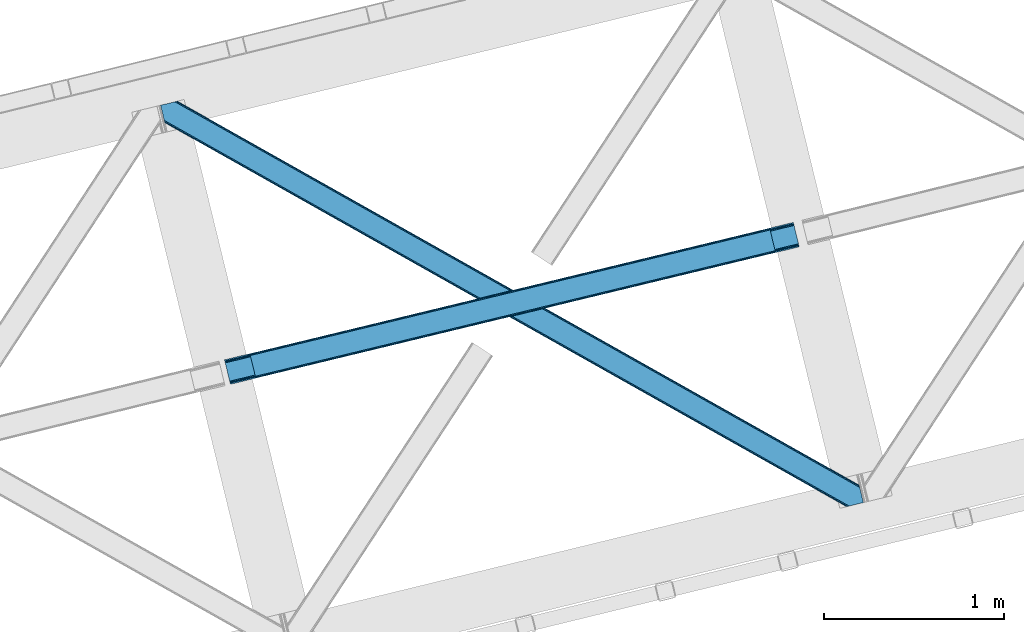
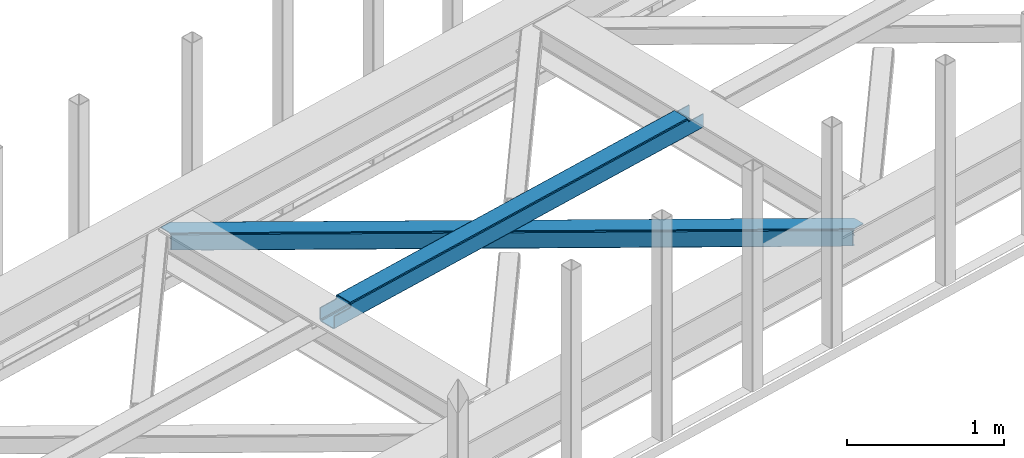
# One storey, part 32 of 67: 1 beam, 1 member.
"""IFC4 building model written with IfcOpenShell, lengths in millimetres."""

from ifc_helpers import new_model, entity, si_unit, converted_unit, derived_unit, direction, frame, origin, place, context, subcontext, project, spatial, triangles, polygons, material, type_object, element, save


model = new_model("IFC4")

# Units and contexts
model_context = context("Model", 3, precision=0.01, world=origin(), true_north=direction((6.12303176911189e-17, 1.0)))
plan_context = context("Plan", 3, precision=0.01, world=origin(), true_north=direction((6.12303176911189e-17, 1.0)))
body_context = subcontext(model_context, "Body", "Model", "MODEL_VIEW")
ifc_project = project(units=[si_unit("LENGTHUNIT", "METRE", prefix="MILLI"), si_unit("AREAUNIT", "SQUARE_METRE"), si_unit("VOLUMEUNIT", "CUBIC_METRE"), converted_unit("PLANEANGLEUNIT", "DEGREE", entity("IfcRatioMeasure", 0.0174532925199433), si_unit("PLANEANGLEUNIT", "RADIAN"), dimensions=[0, 0, 0, 0, 0, 0, 0]), si_unit("MASSUNIT", "GRAM", prefix="KILO"), derived_unit("MASSDENSITYUNIT", [(si_unit("MASSUNIT", "GRAM", prefix="KILO"), 1), (si_unit("LENGTHUNIT", "METRE"), -3)]), derived_unit("MOMENTOFINERTIAUNIT", [(si_unit("LENGTHUNIT", "METRE"), 4)]), si_unit("TIMEUNIT", "SECOND"), si_unit("FREQUENCYUNIT", "HERTZ"), si_unit("THERMODYNAMICTEMPERATUREUNIT", "DEGREE_CELSIUS"), derived_unit("THERMALTRANSMITTANCEUNIT", [(si_unit("MASSUNIT", "GRAM", prefix="KILO"), 1), (si_unit("THERMODYNAMICTEMPERATUREUNIT", "KELVIN"), -1), (si_unit("TIMEUNIT", "SECOND"), -3)]), derived_unit("VOLUMETRICFLOWRATEUNIT", [(si_unit("LENGTHUNIT", "METRE"), 3), (si_unit("TIMEUNIT", "SECOND"), -1)]), derived_unit("MASSFLOWRATEUNIT", [(si_unit("MASSUNIT", "GRAM", prefix="KILO"), 1), (si_unit("TIMEUNIT", "SECOND"), -1)]), derived_unit("ROTATIONALFREQUENCYUNIT", [(si_unit("TIMEUNIT", "SECOND"), -1)]), si_unit("ELECTRICCURRENTUNIT", "AMPERE"), si_unit("ELECTRICVOLTAGEUNIT", "VOLT"), si_unit("POWERUNIT", "WATT"), si_unit("FORCEUNIT", "NEWTON", prefix="KILO"), si_unit("ILLUMINANCEUNIT", "LUX"), si_unit("LUMINOUSFLUXUNIT", "LUMEN"), si_unit("LUMINOUSINTENSITYUNIT", "CANDELA"), derived_unit("USERDEFINED", [(si_unit("MASSUNIT", "GRAM", prefix="KILO"), -1), (si_unit("LENGTHUNIT", "METRE"), -2), (si_unit("TIMEUNIT", "SECOND"), 3), (si_unit("LUMINOUSFLUXUNIT", "LUMEN"), 1)]), derived_unit("LINEARVELOCITYUNIT", [(si_unit("LENGTHUNIT", "METRE"), 1), (si_unit("TIMEUNIT", "SECOND"), -1)]), si_unit("PRESSUREUNIT", "PASCAL"), derived_unit("USERDEFINED", [(si_unit("LENGTHUNIT", "METRE"), -2), (si_unit("MASSUNIT", "GRAM", prefix="KILO"), 1), (si_unit("TIMEUNIT", "SECOND"), -2)]), derived_unit("LINEARFORCEUNIT", [(si_unit("MASSUNIT", "GRAM", prefix="KILO"), 1), (si_unit("LENGTHUNIT", "METRE"), 1), (si_unit("TIMEUNIT", "SECOND"), -2), (si_unit("LENGTHUNIT", "METRE"), -1)]), derived_unit("PLANARFORCEUNIT", [(si_unit("MASSUNIT", "GRAM", prefix="KILO"), 1), (si_unit("LENGTHUNIT", "METRE"), 1), (si_unit("TIMEUNIT", "SECOND"), -2), (si_unit("LENGTHUNIT", "METRE"), -2)])], contexts=[model_context, plan_context])

# Site, building, storey
site_placement = place(None, origin())
site = spatial("IfcSite", under=ifc_project, at=site_placement, CompositionType="ELEMENT")
building_placement = place(site_placement, origin())
building = spatial("IfcBuilding", under=site, at=building_placement, CompositionType="ELEMENT")
storey_placement = place(building_placement, frame((0.0, 0.0, 19800.0)))
storey = spatial("IfcBuildingStorey", under=building, at=storey_placement, CompositionType="ELEMENT", Elevation=19800.0)

# Beam
ifc_material = material(Name="Metal painted (White)")
beam_type = type_object("IfcBeamType", PredefinedType="BEAM")
beam_placement = place(storey_placement, frame((-39359.6097060727, 9545.56841862764, 3967.02760837185)))
element("IfcBeam", 1, at=beam_placement, inside=storey, type_object=beam_type, material=ifc_material, ObjectType="Steel Beam", PredefinedType="BEAM", context=body_context, shape_type="Tessellation", body=[
    polygons([(27.353470961905, 23.8030752188062, 7.0000598235344), (28.9394891671779, 17.2966162719668, 8.33217213033355), (3188.12645728267, 780.539347460429, 9.29712245828728), (3186.55413874494, 787.049116173921, 7.96501433595093), (30.2840504779923, 11.7807067185854, 12.1256988935852), (3189.45863568933, 775.020446263414, 13.0906454392703), (31.1824576232485, 8.09509378632021, 17.8031100519825), (3190.34786187874, 771.332615261155, 18.7680537934142), (31.4979362591613, 6.80087863394741, 24.5000712225218), (3190.65875922441, 770.037293293477, 25.465013564638), (1.65778611891462, 129.216694044932, 24.4999947032322), (1.97326475483608, 127.922478892558, 17.8030351506566), (3161.38389125856, 891.219244755388, 18.7680537934142), (3161.0691284579, 892.513632849746, 25.465013564638), (2.87167190008358, 124.23686596029, 12.1256285998416), (3162.27639442246, 887.532205452699, 13.0906454392703), (4.21623321089799, 118.720956406912, 8.3321087323268), (3163.61076243349, 882.013833252429, 9.29712245828728), (5.80225141617086, 112.214497460073, 7.00000455960104), (3165.18384985803, 875.504250297889, 7.96501433595093), (8.66293703438714e-12, 136.017572678875, 17.4999901436355), (0.315478635912791, 134.723357526499, 10.8030305910599), (1.21388578116896, 131.037744594233, 5.12562404024054), (2.55844709199203, 125.521835040854, 1.33210417273009), (4.1444652972649, 119.015376094016, 0.0), (29.0112570808023, 17.002196584861, 6.37660776192206e-05), (30.5972752860752, 10.4957376380216, 1.3321760728811), (31.9418365968809, 4.97982808464235, 5.12570283613275), (32.8402437421458, 1.29421515237713, 10.8031139945301), (33.1557223780586, 3.24860138789518e-12, 17.5000751650737), (33.1557223780586, 1.08286712929839e-12, 104.492615519572), (31.4979362591526, 6.80087863394633, 104.492615519572), (1.6577861188973, 129.21669404493, 104.492615519572), (0.0, 136.017572678875, 104.492615519572), (3159.42728026612, 899.318362001921, 18.4650138731615), (3159.39928415555, 899.311598290844, 115.472391628142), (3161.04315253146, 892.507357204385, 115.472391628137), (3190.63278329797, 770.031017648118, 115.472391628137), (3192.27665167388, 763.226776561658, 115.472391628137), (3192.30464778445, 763.233540272735, 18.4650138731615), (3191.99375043879, 764.528862240413, 11.7680541019377), (3191.10452424939, 768.216693242674, 6.09064574779806), (3189.77234584272, 773.735594439689, 2.29712276681504), (3188.200027305, 780.245363153179, 0.965014644474365), (3163.54200166624, 882.308979450066, 0.965014644474365), (3161.96891424171, 888.818562404604, 2.29712276681504), (3160.63454623068, 894.336934604878, 6.09064574779806), (3159.74204306677, 898.023973907563, 11.7680541019377), (161.750823822574, 38.2692819454433, 104.492615519559), (165.531158526742, 39.1825906585835, 106.103528223035), (169.311493230918, 40.0958993717227, 107.714440926506), (170.877359135682, 40.4742042273367, 111.603528223046), (172.443225040463, 40.8525090829539, 115.492615519574), (3059.3968274947, 738.325110290198, 116.424924587822), (3059.39682749469, 738.325110290198, 115.472391628142), (163.408609941463, 31.4684033114959, 104.492615519598), (167.188944645622, 32.3817120246361, 106.103528223082), (170.969279349807, 33.2950207377775, 107.71444092654), (172.535145254588, 33.6733255933936, 111.603528223046), (174.10101115936, 34.0516304490098, 115.492615519574), (3061.0546136136, 731.524231656253, 115.472391628142), (3061.0546136136, 731.524231656253, 123.424929147419), (174.10101115936, 34.0516304490109, 122.543130490485), (140.945288781319, 170.069203127884, 115.492615519574), (142.60293422888, 163.268906601355, 115.492734192455), (142.918741097907, 161.973333198349, 122.239852351631), (143.816960681394, 158.288496409301, 127.91742174054), (145.161521992199, 152.772586855922, 131.710948503787), (146.747540197472, 146.266127909081, 133.04306081059), (168.298759743206, 57.8547056678149, 133.043116074524), (169.884777948479, 51.3482467209744, 131.711011901798), (171.229339259285, 45.832337167593, 127.917492034279), (172.127746404541, 42.14672423533, 122.24008548346), (173.785532523456, 35.3458456013869, 129.240090043056), (172.8871253782, 39.03145853365, 134.91749659388), (171.542564067385, 44.5473680870303, 138.711016461395), (169.956545862112, 51.0538270338696, 140.04312063412), (145.089754078575, 153.067006543024, 140.043056868043), (143.503735873302, 159.573465489864, 138.710944561244), (142.159174562479, 165.089375043246, 134.917417797992), (141.260767417223, 168.774987975509, 129.24000663959), (140.945288781319, 170.069203127884, 122.543045469051), (3027.89889123554, 867.541804335125, 115.472391628142), (3027.89889123554, 867.541804335125, 123.424844125981), (3028.21436987146, 866.24758918275, 130.121805296524), (3029.11277701672, 862.561976250487, 135.799216454922), (3030.45733832753, 857.046066697107, 139.592743218173), (3032.04335653281, 850.539607750265, 140.924855524977), (3056.91014831634, 748.526428241115, 140.92491929105), (3058.49616652162, 742.019969294273, 139.592815118324), (3059.84072783243, 736.504059740891, 135.79929525081), (3060.73913497768, 732.81844680863, 130.121888699995), (3059.08134885878, 739.619325442571, 123.121884140394), (3058.18294171352, 743.304938374836, 128.799290691213), (3056.83838040271, 748.820847928216, 132.592810558728), (3055.25236219744, 755.327306875058, 133.924914731454), (3033.7011426517, 843.738729116322, 133.92485946752), (3032.11512444643, 850.245188063164, 132.592747160721), (3030.77056313562, 855.761097616546, 128.799220397465), (3029.87196706965, 859.447492315395, 123.121968615998), (3029.55686627516, 860.74014393459, 116.424688691599), (3029.55667735445, 860.740925701182, 115.472391628137), (141.037208995435, 162.890019638321, 111.603528223046), (139.471343090654, 162.511714782705, 107.714440926519), (135.691008386478, 161.598406069563, 106.103528223061), (131.91067368231, 160.685097356424, 104.492615519585), (139.379422876529, 169.690898272263, 111.603528223046), (137.813556971757, 169.312593416649, 107.714440926506), (134.033222267598, 168.399284703513, 106.103528223009), (130.252887563421, 167.485975990372, 104.492615519546)], [[[1, 2, 3, 4]], [[2, 5, 6, 3]], [[5, 7, 8, 6]], [[7, 9, 10, 8]], [[11, 12, 13, 14]], [[12, 15, 16, 13]], [[15, 17, 18, 16]], [[17, 19, 20, 18]], [[19, 1, 4, 20]], [[21, 22, 23, 24, 25, 26, 27, 28, 29, 30, 31, 32, 9, 7, 5, 2, 1, 19, 17, 15, 12, 11, 33, 34]], [[35, 36, 37, 14, 13, 16, 18, 20, 4, 3, 6, 8, 10, 38, 39, 40, 41, 42, 43, 44, 45, 46, 47, 48]], [[9, 32, 49, 50, 51, 52, 53, 54, 55, 38, 10]], [[56, 57, 50, 49]], [[57, 58, 51, 50]], [[58, 59, 52, 51]], [[59, 60, 53, 52]], [[56, 49, 32, 31]], [[56, 31, 30, 40, 39, 61, 62, 63, 60, 59, 58, 57]], [[64, 65, 66, 67, 68, 69, 70, 71, 72, 73, 53, 60, 63, 74, 75, 76, 77, 78, 79, 80, 81, 82]], [[61, 39, 38, 55]], [[83, 84, 85, 86, 87, 88, 89, 90, 91, 92, 62, 61, 55, 54, 93, 94, 95, 96, 97, 98, 99, 100, 101, 102]], [[96, 95, 71, 70]], [[95, 94, 72, 71]], [[94, 93, 73, 72]], [[93, 54, 53, 73]], [[70, 69, 97, 96]], [[101, 100, 66, 65]], [[100, 99, 67, 66]], [[99, 98, 68, 67]], [[98, 97, 69, 68]], [[33, 11, 14, 37, 102, 101, 65, 103, 104, 105, 106]], [[64, 107, 103, 65]], [[107, 108, 104, 103]], [[108, 109, 105, 104]], [[109, 110, 106, 105]], [[34, 33, 106, 110]], [[36, 83, 102, 37]], [[30, 29, 41, 40]], [[29, 28, 42, 41]], [[28, 27, 43, 42]], [[27, 26, 44, 43]], [[44, 26, 25, 45]], [[25, 24, 46, 45]], [[24, 23, 47, 46]], [[23, 22, 48, 47]], [[22, 21, 35, 48]], [[35, 21, 34, 110, 109, 108, 107, 64, 82, 84, 83, 36]], [[62, 92, 74, 63]], [[92, 91, 75, 74]], [[91, 90, 76, 75]], [[90, 89, 77, 76]], [[88, 78, 77, 89]], [[88, 87, 79, 78]], [[87, 86, 80, 79]], [[86, 85, 81, 80]], [[85, 84, 82, 81]]], closed=True),
])

# Member
member_type = type_object("IfcMemberType", PredefinedType="BRACE")
member_placement = place(storey_placement, frame((-39714.5107543945, 8865.52281188965, 3823.99987792968)))
element("IfcMember", 2, at=member_placement, inside=storey, type_object=member_type, ObjectType="Steel Horizontal Brace", PredefinedType="BRACE", context=body_context, shape_type="Tessellation", body=[
    triangles([(3809.33957519531, 0.0, 122.499499511719), (3811.23480834961, 0.462181091308594, 129.196765136719), (23.4590332031294, 2133.54767761231, 129.196765136719), (23.8869140625029, 2131.77569274902, 122.499499511719), (3816.62982788086, 1.77721710205151, 134.87548828125), (22.2265502929731, 2138.59388122559, 134.87548828125), (3824.70375366211, 3.74512023925854, 138.668280029298), (20.3848022460952, 2146.14690856934, 138.668280029298), (3834.22875366211, 6.06707153320349, 140.00075683594), (18.2128417968779, 2155.05566711426, 140.00075683594), (1916.9806640625, 1065.68146362305, 17.5012573242202), (2556.11607055664, 705.752851867675, 17.5012573242202), (3195.24915161133, 345.823658752443, 17.5012573242202), (3809.33957519531, 0.0, 17.5012573242202), (1277.84525756836, 1425.61065673828, 17.5012573242202), (638.709851074222, 1785.53868713379, 17.5012573242202), (23.8869140625029, 2131.77569274902, 17.5012573242202), (3885.46051025391, 97.721360778809, 140.00075683594), (3903.67567749024, 22.9951080322262, 140.00075683594), (69.4469238281235, 2246.709375, 140.00075683594), (0.0, 2229.78133850098, 140.00075683594), (3883.28854980469, 106.63011932373, 138.668280029298), (78.971923828125, 2249.03132629395, 138.668280029298), (3881.44680175781, 114.182565307618, 134.87548828125), (87.0458496093779, 2250.99981079102, 134.87548828125), (3880.21664428711, 119.229350280762, 129.196765136719), (92.4408691406279, 2252.31600952148, 129.196765136719), (3879.78643798828, 121.001335144043, 122.499499511719), (94.3337768554702, 2252.77760925293, 122.499499511719), (3265.41928710938, 466.982542419433, 17.5012573242202), (3879.78643798828, 121.001335144043, 17.5012573242202), (2626.29318237305, 826.905340576172, 17.5012573242202), (1987.16940307617, 1186.82755737305, 17.5012573242202), (708.921844482422, 1906.67315368652, 17.5012573242202), (94.3337768554702, 2252.77760925293, 17.5012573242202), (1348.0456237793, 1546.75093688965, 17.5012573242202), (82.4833374023438, 2249.88825073242, 122.197192382813), (69.0143920898481, 2246.60473022461, 131.668707275392), (59.4893920898467, 2244.28277893066, 133.001184082033), (0.0, 2229.78133850098, 133.001184082033), (77.0883178710938, 2248.57321472168, 127.873590087893), (84.3808959960952, 2250.34985046387, 24.5008300781265), (77.0883178710938, 2248.57321472168, 12.1248413085959), (91.5851074218735, 2252.1067199707, 9.49942016601563), (82.4833374023438, 2249.88825073242, 17.8035644531265), (84.3808959960952, 2250.34985046387, 115.499926757813), (72.3118652343765, 2247.40816955567, 9.49942016601563), (92.0548461914077, 2252.22066650391, 10.8691040039084), (1983.48823242188, 1180.86745605469, 24.5008300781265), (3882.05606689453, 111.689694213868, 115.499926757813), (2626.78617553711, 818.593057250977, 24.5008300781265), (3270.08876953125, 456.31923980713, 24.5008300781265), (3882.05606689453, 111.689694213868, 24.5008300781265), (1340.18796386719, 1543.14069213867, 24.5008300781265), (696.8876953125, 1905.41509094238, 24.5008300781265), (3882.48627319336, 109.917127990722, 122.197192382813), (3883.71643066406, 104.870924377441, 127.873590087893), (3885.55817871094, 97.3184783935558, 131.668707275392), (3887.73013916016, 88.4097198486324, 133.001184082033), (3883.71643066406, 104.870924377441, 12.1248413085959), (3885.4163269043, 97.899838256837, 8.52041015625218), (3880.58871459961, 117.702699279786, 8.52041015625218), (3903.67567749024, 22.9951080322262, 133.001184082033), (3882.48627319336, 109.917127990722, 17.8035644531265), (3880.37244873047, 118.590435791017, 10.9365417480476), (3844.18628540039, 8.49424896240271, 133.001184082033), (15.9432128906265, 2164.3678894043, 133.001184082033), (3834.66128540039, 6.17229766845776, 131.668707275392), (18.1151733398438, 2155.45796813965, 131.668707275392), (3826.58735961915, 4.20439453125073, 127.873590087893), (19.9569213867217, 2147.90610351562, 127.873590087893), (3821.19001464844, 2.88819580078234, 122.197192382813), (21.1894042968779, 2142.85989990234, 122.197192382813), (3819.29478149414, 2.42717742919922, 115.499926757813), (21.6172851562515, 2141.08791503906, 115.499926757813), (3208.50183105469, 346.395716857911, 24.5008300781265), (3819.29478149414, 2.42717742919922, 24.5008300781265), (2565.16435546875, 708.690463256837, 24.5008300781265), (1921.82687988281, 1070.98579101563, 24.5008300781265), (635.15192871094, 1795.57528381348, 24.5008300781265), (21.6172851562515, 2141.08791503906, 24.5008300781265), (1278.49172973633, 1433.27995605469, 24.5008300781265), (21.1894042968779, 2142.85989990234, 17.8035644531265), (23.2590454101592, 2134.34995422363, 9.49942016601563), (19.9569213867217, 2147.90610351562, 12.1248413085959), (23.3706665039063, 2133.90928344727, 10.8691040039084), (18.8686157226548, 2152.37676086426, 9.49942016601563), (3826.58735961915, 4.20439453125073, 12.1248413085959), (3812.86494140625, 0.859831237792605, 8.52041015625218), (3821.19001464844, 2.88819580078234, 17.8035644531265), (3834.03806762696, 6.02056274414099, 8.52041015625218), (3811.91616210937, 0.628450012207395, 10.9365417480476), (190.667431640628, 2055.62685241699, 9.49942016601563), (195.062512207034, 2037.60120849609, 9.49942016601563), (196.076403808598, 2037.66864624023, 8.49948120117188), (196.053149414067, 2037.42331237793, 8.8831787109375), (191.290649414063, 2056.67097473145, 8.85294799804615), (195.732238769531, 2037.48144836426, 9.08316650390771), (191.346459960936, 2055.82567749023, 9.20641479492406), (195.383422851563, 2037.54307250977, 9.29943237304906), (191.006945800786, 2055.72684631348, 9.35291748046802), (191.234838867189, 2057.51627197266, 8.49948120117188), (150.921020507813, 2218.6901550293, 9.49942016601563), (155.311450195317, 2200.6645111084, 9.49942016601563), (151.251232910159, 2218.34947814941, 9.25757446289208), (155.813745117186, 2200.23779296875, 9.42500610351635), (151.60469970703, 2217.98438415527, 8.99945068359375), (156.250927734378, 2199.30529174805, 9.11804809570458), (151.962817382817, 2217.61929016113, 8.74132690429906), (156.692761230472, 2198.36348876953, 8.80643920898365), (152.293029785156, 2217.27861328125, 8.49948120117188), (157.129943847656, 2197.43215026855, 8.49948120117188), (3713.61518554688, 194.649165344239, 8.52041015625218), (3708.78989868164, 214.452026367188, 8.52041015625218), (3713.26636962891, 194.529986572266, 8.40181274414135), (3708.39689941407, 214.570623779297, 8.37390747070458), (3713.06173095703, 194.459642028809, 8.3320495605476), (3708.00390014648, 214.689221191407, 8.22740478515698), (3707.90390625, 214.477606201172, 7.87393798828271), (3713.112890625, 193.949789428711, 8.19484863281468), (3707.80391235352, 214.265991210938, 7.52047119140843), (3713.23846435547, 192.705097961427, 7.85765991211156), (3713.36403808594, 191.464476013183, 7.52047119140843), (3264.76351318359, 465.821566772462, 10.8039916992202), (3262.90316162109, 462.516535949708, 5.12526855468968), (3260.1149597168, 457.569163513184, 1.33247680664135), (3708.58060913086, 211.08769683838, 5.59500732422021), (708.268395996092, 1905.51275939941, 10.8039916992202), (706.405718994145, 1902.2071472168, 5.12526855468968), (153.148791503911, 2213.77533874512, 5.12526855468968), (703.619842529297, 1897.25977478027, 1.33247680664135), (154.985888671879, 2206.22231140137, 1.33247680664135), (700.333996582034, 1891.42524719238, 0.0), (157.157849121097, 2197.31355285645, 0.0), (3710.29445800781, 204.051498413086, 1.33247680664135), (3712.46641845704, 195.142739868164, 0.0), (3256.82911376953, 451.73405456543, 0.0), (2625.63973388672, 825.7443649292, 10.8039916992202), (1986.5136291504, 1185.66716308594, 10.8039916992202), (1347.39217529297, 1545.59054260254, 10.8039916992202), (2623.77938232422, 822.439334106446, 5.12526855468968), (1984.6532775879, 1182.36155090332, 5.12526855468968), (1345.53182373047, 1542.28493041992, 5.12526855468968), (2620.99350585938, 817.492543029786, 1.33247680664135), (1981.86740112305, 1177.4141784668, 1.33247680664135), (1342.74362182617, 1537.3375579834, 1.33247680664135), (2617.70765991211, 811.656852722168, 0.0), (1978.58155517578, 1171.57965087891, 0.0), (1339.45777587891, 1531.50303039551, 0.0), (3746.51550292969, 55.4634750366222, 0.0), (3203.83699951172, 361.072146606446, 0.0), (2564.70391845703, 721.001339721681, 0.0), (1925.56618652344, 1080.92937011719, 0.0), (1286.43310546875, 1440.85856323242, 0.0), (647.300024414064, 1800.78775634766, 0.0), (191.206933593749, 2057.63486938477, 0.0), (3195.90492553711, 346.985215759278, 10.8039916992202), (639.365624999999, 1786.6990814209, 10.8039916992202), (641.225976562499, 1790.00469360352, 5.12526855468968), (195.220642089844, 2041.17308349609, 5.12526855468968), (3197.76527709961, 350.290246582032, 5.12526855468968), (3200.55115356445, 355.237037658691, 1.33247680664135), (3748.6874633789, 46.554135131837, 1.33247680664135), (3752.57792358399, 34.8100845336921, 8.52041015625218), (3750.40131225586, 39.517936706543, 5.59500732422021), (3751.17568359375, 36.3396423339855, 7.52047119140843), (3752.23840942383, 35.1804107666012, 8.278564453125), (644.011853027347, 1794.95206604004, 1.33247680664135), (193.378894042973, 2048.72611083984, 1.33247680664135), (2561.41574707031, 715.165649414063, 1.33247680664135), (1922.28266601563, 1075.0948425293, 1.33247680664135), (1283.14725952149, 1435.0228729248, 1.33247680664135), (2558.63219604492, 710.218858337403, 5.12526855468968), (1919.49446411133, 1070.14747009277, 5.12526855468968), (1280.36138305664, 1430.07666320801, 5.12526855468968), (2556.76951904297, 706.913246154785, 10.8039916992202), (1917.63411254883, 1066.84185791016, 10.8039916992202), (1278.50103149414, 1426.77105102539, 10.8039916992202), (3745.61788330078, 59.1411575317379, 7.52047119140843), (3746.13645629883, 57.3430114746097, 7.90416870117406), (3746.6736328125, 56.436090087891, 8.10880737304615), (3747.29917602539, 55.37627105713, 8.34832763671875), (3747.7503112793, 54.6129455566406, 8.52041015625218), (3211.01563110352, 350.861723327636, 12.1248413085959), (3217.08735351563, 361.643623352051, 6.99957275390625), (3213.80150756836, 355.808514404298, 8.3320495605476), (3744.24587402344, 64.7751159667969, 6.99957275390625), (643.742102050783, 1810.82319030762, 6.99957275390625), (188.937304687504, 2066.94592895508, 6.99957275390625), (637.668054199217, 1800.0412902832, 12.1248413085959), (640.458581542967, 1804.98866271973, 8.3320495605476), (635.807702636717, 1796.73567810059, 17.8035644531265), (3209.15527954102, 347.556111145021, 17.8035644531265), (2565.81780395508, 709.850857543946, 17.8035644531265), (1922.48032836914, 1072.14618530273, 17.8035644531265), (1279.1428527832, 1434.4403503418, 17.8035644531265), (2567.67815551758, 713.156469726562, 12.1248413085959), (1924.3430053711, 1075.45179748535, 12.1248413085959), (1281.00785522461, 1437.74712524414, 12.1248413085959), (2570.46403198242, 718.103260803224, 8.3320495605476), (1927.12888183594, 1080.39800720215, 8.3320495605476), (1283.79373168945, 1442.69333496094, 8.3320495605476), (2573.74987792969, 723.938369750977, 6.99957275390625), (1930.41705322266, 1086.23369750977, 6.99957275390625), (1287.07957763672, 1448.52902526856, 6.99957275390625), (694.371569824223, 1900.94908447266, 12.1248413085959), (691.590344238284, 1896.00287475586, 8.3320495605476), (157.264819335942, 2196.88450927734, 8.41343994140698), (159.427478027348, 2188.00133056641, 6.99957275390625), (3261.50092163086, 441.070751953126, 6.99957275390625), (3264.78676757812, 446.906442260743, 8.3320495605476), (3714.73604736328, 185.830517578126, 6.99957275390625), (3267.57264404297, 451.852651977539, 12.1248413085959), (688.302172851567, 1890.16718444824, 6.99957275390625), (696.236572265625, 1904.25469665527, 17.8035644531265), (3269.43532104493, 455.158264160156, 17.8035644531265), (2621.48649902344, 809.179678344726, 8.3320495605476), (2618.20065307617, 803.344569396973, 6.99957275390625), (1978.18855590821, 1171.45407714844, 8.3320495605476), (1974.90038452148, 1165.61838684082, 6.99957275390625), (1331.60244140625, 1527.89278564453, 6.99957275390625), (1334.88828735352, 1533.72847595215, 8.3320495605476), (2624.27470092774, 814.12705078125, 12.1248413085959), (1980.97210693359, 1176.40144958496, 12.1248413085959), (1337.67416381836, 1538.67468566895, 12.1248413085959), (2626.13505249024, 817.432081604004, 17.8035644531265), (1982.83478393555, 1179.70706176758, 17.8035644531265), (1339.53451538086, 1541.98029785156, 17.8035644531265)], [[1, 2, 3], [3, 4, 1], [2, 5, 6], [6, 3, 2], [5, 7, 8], [8, 6, 5], [7, 9, 10], [10, 8, 7], [11, 1, 4], [1, 12, 13], [11, 12, 1], [13, 14, 1], [15, 4, 16], [4, 15, 11], [17, 16, 4], [9, 18, 10], [9, 19, 18], [20, 10, 18], [21, 10, 20], [18, 22, 23], [23, 20, 18], [22, 24, 25], [25, 23, 22], [24, 26, 27], [27, 25, 24], [26, 28, 29], [29, 27, 26], [30, 28, 31], [28, 30, 32], [28, 33, 29], [33, 28, 32], [34, 35, 29], [36, 29, 33], [29, 36, 34], [37, 29, 27], [38, 23, 20], [21, 39, 20], [39, 21, 40], [39, 38, 20], [41, 23, 38], [41, 37, 25], [25, 23, 41], [27, 25, 37], [42, 35, 29], [43, 44, 45], [37, 46, 29], [43, 47, 44], [42, 45, 35], [46, 42, 29], [48, 35, 45], [45, 44, 48], [49, 50, 46], [50, 51, 52], [49, 51, 50], [52, 53, 50], [54, 46, 55], [46, 54, 49], [42, 55, 46], [50, 56, 46], [37, 46, 56], [56, 57, 37], [41, 37, 57], [57, 58, 41], [38, 41, 58], [58, 59, 38], [39, 38, 59], [57, 24, 22], [60, 61, 62], [24, 57, 56], [58, 57, 22], [58, 18, 59], [19, 59, 18], [59, 19, 63], [58, 22, 18], [31, 28, 53], [62, 64, 60], [64, 31, 53], [65, 64, 62], [65, 31, 64], [28, 50, 53], [56, 26, 24], [28, 26, 56], [50, 28, 56], [59, 66, 67], [66, 59, 63], [67, 39, 59], [40, 39, 67], [66, 68, 67], [69, 67, 68], [68, 70, 69], [71, 69, 70], [70, 72, 71], [73, 71, 72], [72, 74, 73], [75, 73, 74], [76, 74, 77], [74, 76, 78], [74, 79, 75], [79, 74, 78], [80, 81, 75], [82, 75, 79], [75, 82, 80], [83, 84, 85], [81, 4, 17], [17, 86, 83], [86, 84, 83], [83, 81, 17], [75, 4, 81], [73, 71, 6], [3, 73, 6], [3, 4, 73], [75, 73, 4], [71, 8, 6], [69, 8, 71], [87, 85, 84], [69, 67, 10], [69, 10, 8], [67, 21, 10], [67, 40, 21], [72, 1, 2], [68, 7, 9], [19, 66, 9], [66, 19, 63], [66, 68, 9], [70, 7, 68], [70, 72, 5], [5, 7, 70], [2, 5, 72], [77, 14, 1], [88, 89, 90], [72, 74, 1], [88, 91, 89], [77, 90, 14], [74, 77, 1], [92, 14, 90], [90, 89, 92], [93, 94, 84], [84, 87, 93], [95, 96, 97], [96, 98, 99], [99, 98, 100], [101, 100, 94], [94, 93, 101], [100, 101, 99], [99, 97, 96], [97, 102, 95], [103, 104, 44], [47, 44, 104], [105, 106, 104], [107, 108, 106], [109, 110, 108], [111, 112, 110], [110, 109, 111], [108, 107, 109], [106, 105, 107], [104, 103, 105], [62, 61, 113], [113, 114, 62], [115, 116, 114], [117, 118, 116], [116, 115, 117], [119, 118, 120], [121, 119, 122], [122, 123, 121], [120, 122, 119], [117, 120, 118], [114, 113, 115], [124, 30, 31], [125, 124, 118], [118, 119, 125], [119, 121, 125], [124, 65, 114], [114, 116, 124], [116, 118, 124], [65, 62, 114], [126, 125, 127], [48, 128, 103], [128, 129, 130], [130, 111, 128], [128, 109, 107], [109, 128, 111], [128, 105, 103], [105, 128, 107], [128, 48, 35], [35, 34, 128], [103, 44, 48], [129, 131, 132], [132, 130, 129], [131, 133, 134], [134, 132, 131], [135, 136, 137], [137, 126, 135], [127, 135, 126], [121, 127, 125], [31, 65, 124], [30, 124, 138], [138, 32, 30], [32, 138, 33], [139, 33, 138], [33, 139, 36], [140, 36, 139], [36, 140, 34], [128, 34, 140], [124, 125, 138], [141, 138, 125], [138, 141, 142], [142, 139, 138], [139, 142, 143], [143, 140, 139], [140, 143, 129], [129, 128, 140], [125, 126, 144], [144, 141, 125], [141, 144, 145], [145, 142, 141], [142, 145, 146], [146, 143, 142], [143, 146, 129], [131, 129, 146], [126, 137, 144], [147, 144, 137], [144, 147, 145], [148, 145, 147], [145, 148, 146], [149, 146, 148], [146, 149, 131], [133, 131, 149], [136, 150, 151], [137, 151, 147], [151, 137, 136], [148, 152, 153], [152, 147, 151], [148, 147, 152], [133, 149, 154], [153, 149, 148], [149, 153, 154], [155, 133, 154], [156, 133, 155], [134, 133, 156], [157, 92, 14], [158, 16, 17], [159, 96, 95], [158, 86, 94], [94, 159, 158], [94, 98, 159], [86, 84, 94], [95, 160, 159], [161, 162, 163], [92, 157, 164], [157, 161, 165], [165, 166, 157], [167, 164, 157], [157, 166, 167], [164, 89, 92], [163, 165, 161], [150, 163, 162], [162, 151, 150], [155, 168, 169], [169, 156, 155], [168, 159, 160], [160, 169, 168], [17, 86, 158], [14, 13, 157], [151, 162, 152], [170, 152, 162], [152, 170, 171], [171, 153, 152], [153, 171, 172], [172, 154, 153], [154, 172, 168], [168, 155, 154], [162, 161, 173], [173, 170, 162], [170, 173, 171], [174, 171, 173], [171, 174, 172], [175, 172, 174], [172, 175, 168], [159, 168, 175], [161, 157, 176], [176, 173, 161], [173, 176, 174], [177, 174, 176], [174, 177, 175], [178, 175, 177], [175, 178, 159], [158, 159, 178], [157, 13, 12], [12, 176, 157], [176, 12, 11], [11, 177, 176], [177, 11, 15], [15, 178, 177], [178, 15, 16], [16, 158, 178], [166, 179, 180], [166, 180, 181], [167, 181, 182], [167, 182, 183], [91, 89, 183], [164, 183, 89], [184, 183, 182], [88, 91, 183], [183, 184, 88], [185, 180, 179], [182, 185, 186], [182, 181, 185], [180, 185, 181], [179, 187, 185], [188, 189, 102], [93, 85, 190], [93, 87, 85], [102, 190, 191], [190, 102, 97], [97, 99, 190], [80, 192, 81], [83, 81, 192], [192, 190, 83], [85, 83, 190], [102, 191, 188], [182, 186, 184], [90, 88, 184], [184, 193, 90], [77, 90, 193], [193, 76, 77], [76, 193, 78], [194, 78, 193], [78, 194, 195], [195, 79, 78], [79, 195, 82], [196, 82, 195], [82, 196, 80], [192, 80, 196], [193, 184, 197], [197, 194, 193], [194, 197, 195], [198, 195, 197], [195, 198, 196], [199, 196, 198], [196, 199, 190], [190, 192, 196], [184, 186, 197], [200, 197, 186], [197, 200, 198], [201, 198, 200], [198, 201, 202], [202, 199, 198], [199, 202, 191], [191, 190, 199], [186, 185, 203], [203, 200, 186], [200, 203, 204], [204, 201, 200], [201, 204, 205], [205, 202, 201], [202, 205, 191], [188, 191, 205], [206, 106, 108], [108, 207, 206], [108, 110, 207], [110, 208, 207], [104, 206, 43], [43, 47, 104], [207, 208, 209], [210, 123, 122], [122, 211, 210], [122, 117, 211], [210, 212, 123], [213, 211, 117], [61, 60, 113], [213, 113, 60], [209, 214, 207], [206, 215, 45], [45, 43, 206], [215, 55, 42], [42, 45, 215], [64, 53, 216], [52, 216, 53], [60, 64, 213], [216, 213, 64], [210, 211, 217], [217, 218, 210], [218, 217, 219], [219, 220, 218], [220, 219, 221], [222, 221, 219], [221, 222, 207], [207, 214, 221], [211, 213, 217], [223, 217, 213], [217, 223, 219], [224, 219, 223], [219, 224, 222], [225, 222, 224], [222, 225, 207], [206, 207, 225], [213, 216, 226], [226, 223, 213], [223, 226, 227], [227, 224, 223], [224, 227, 228], [228, 225, 224], [225, 228, 215], [215, 206, 225], [216, 52, 51], [51, 226, 216], [226, 51, 227], [49, 227, 51], [227, 49, 228], [54, 228, 49], [228, 54, 215], [55, 215, 54], [209, 134, 189], [132, 208, 130], [208, 132, 134], [130, 208, 111], [134, 209, 208], [189, 134, 156], [169, 102, 156], [102, 169, 160], [156, 102, 189], [160, 95, 102], [136, 212, 187], [123, 127, 121], [136, 123, 212], [123, 135, 127], [123, 136, 135], [150, 136, 187], [179, 150, 187], [165, 179, 166], [179, 163, 150], [179, 165, 163], [203, 185, 210], [210, 218, 203], [218, 204, 203], [204, 218, 220], [185, 212, 210], [185, 187, 212], [214, 188, 221], [188, 214, 189], [209, 189, 214], [205, 221, 188], [220, 205, 204], [221, 205, 220]]),
])

save(model, "model.ifc")
